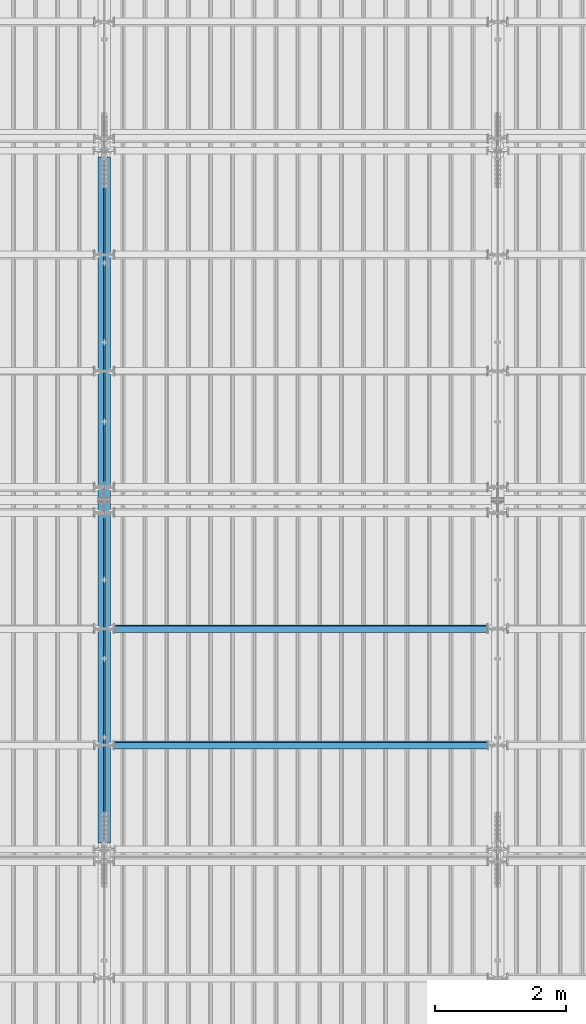
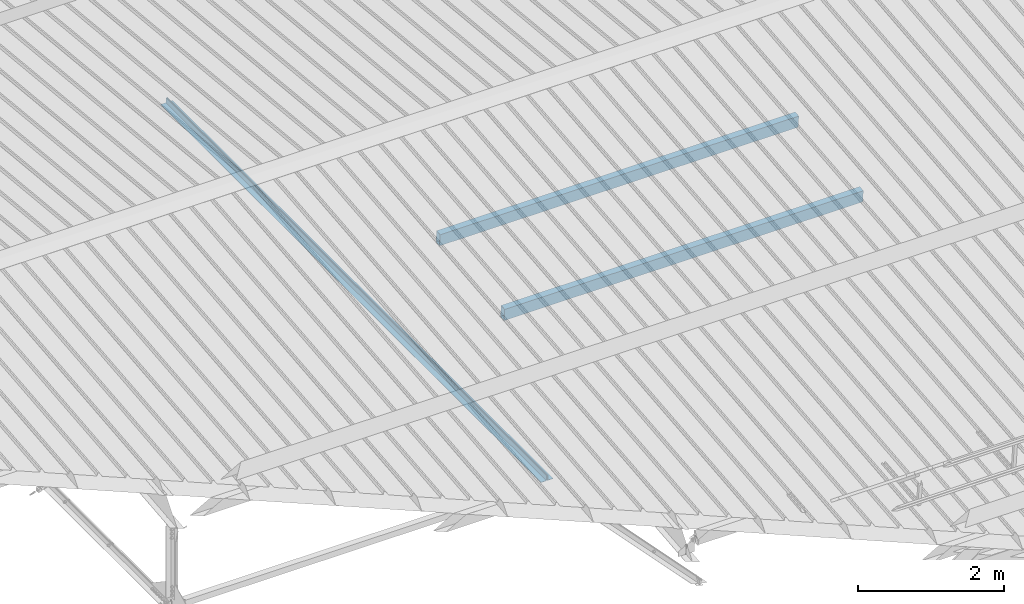
# One storey, part 256 of 709: 4 beams, 4 elements without a shape of their own.
"""IFC4 building model written with IfcOpenShell, lengths in millimetres."""

from ifc_helpers import new_model, si_unit, direction, frame, origin_with_axes, place, context, subcontext, project, spatial, polygons, material, element, aggregate, save


model = new_model("IFC4")

# Units and contexts
model_context = context("Model", 3, precision=0.2, world=origin_with_axes(), true_north=direction((0.0, 1.0)))
body_context = subcontext(model_context, "Body", "Model", "MODEL_VIEW")
ifc_project = project(units=[si_unit("LENGTHUNIT", "METRE", prefix="MILLI"), si_unit("AREAUNIT", "SQUARE_METRE"), si_unit("VOLUMEUNIT", "CUBIC_METRE"), si_unit("MASSUNIT", "GRAM", prefix="KILO"), si_unit("TIMEUNIT", "SECOND"), si_unit("PLANEANGLEUNIT", "RADIAN"), si_unit("SOLIDANGLEUNIT", "STERADIAN"), si_unit("THERMODYNAMICTEMPERATUREUNIT", "DEGREE_CELSIUS"), si_unit("LUMINOUSINTENSITYUNIT", "LUMEN")], contexts=[model_context])

# Site, building, storey
site_placement = place(None, origin_with_axes())
site = spatial("IfcSite", under=ifc_project, at=site_placement, CompositionType="ELEMENT")
building_placement = place(site_placement, origin_with_axes())
building = spatial("IfcBuilding", under=site, at=building_placement, Name="Undefined", CompositionType="ELEMENT")
storey_placement = place(building_placement, origin_with_axes())
storey = spatial("IfcBuildingStorey", under=building, at=storey_placement, Name="Undefined", CompositionType="ELEMENT", Elevation=0.0)

# Assembly, beam
assembly_1_placement = place(storey_placement, frame((15949.0, 5673.0, 6045.00002), z_axis=(0.0, 0.0, 1.0), x_axis=(0.0, 1.0, 0.0)))
assembly_1 = element("IfcElementAssembly", 1, at=assembly_1_placement, inside=storey)
ifc_material_1 = material(Name="C345-5", Category="STEEL")
beam_1_placement = place(assembly_1_placement, origin_with_axes())
beam_1 = element("IfcBeam", 2, at=beam_1_placement, material=ifc_material_1, ObjectType="433", context=body_context, shape_type="Tessellation", body=[
    polygons([(100.0, -45.0, -45.0), (100.0, 45.0, -45.0), (10554.0, 45.0, -45.0), (10554.0, -45.0, -45.0), (100.0, 45.0, -39.0), (10554.0, 45.0, -39.0), (100.0, -39.0, -39.0), (10554.0, -39.0, -39.0), (100.0, -39.0, 45.0), (10554.0, -39.0, 45.0), (100.0, -45.0, 45.0), (10554.0, -45.0, 45.0)], [[[1, 2, 3, 4]], [[2, 5, 6, 3]], [[5, 7, 8, 6]], [[7, 9, 10, 8]], [[9, 11, 12, 10]], [[11, 1, 4, 12]], [[6, 8, 10, 12, 4, 3]], [[11, 9, 7, 5, 2, 1]]], closed=True),
])
aggregate(assembly_1, [beam_1])

assembly_2_placement = place(storey_placement, frame((16051.0, 16327.0, 6045.00002), z_axis=(0.0, 0.0, 1.0), x_axis=(0.0, -1.0, 0.0)))
assembly_2 = element("IfcElementAssembly", 3, at=assembly_2_placement, inside=storey)
beam_2_placement = place(assembly_2_placement, origin_with_axes())
beam_2 = element("IfcBeam", 4, at=beam_2_placement, material=ifc_material_1, ObjectType="434", context=body_context, shape_type="Tessellation", body=[
    polygons([(100.0, -45.0, -45.0), (100.0, 45.0, -45.0), (10554.0, 45.0, -45.0), (10554.0, -45.0, -45.0), (100.0, 45.0, -39.0), (10554.0, 45.0, -39.0), (100.0, -39.0, -39.0), (10554.0, -39.0, -39.0), (100.0, -39.0, 45.0), (10554.0, -39.0, 45.0), (100.0, -45.0, 45.0), (10554.0, -45.0, 45.0)], [[[1, 2, 3, 4]], [[2, 5, 6, 3]], [[5, 7, 8, 6]], [[7, 9, 10, 8]], [[9, 11, 12, 10]], [[11, 1, 4, 12]], [[6, 8, 10, 12, 4, 3]], [[11, 9, 7, 5, 2, 1]]], closed=True),
])
aggregate(assembly_2, [beam_2])

assembly_3_placement = place(storey_placement, frame((16000.0, 7263.34988, 7854.7991), z_axis=(0.0, 0.9950371902, 0.099503719), x_axis=(1.0, 0.0, 0.0)))
assembly_3 = element("IfcElementAssembly", 5, at=assembly_3_placement, inside=storey)
ifc_material_2 = material(Name="C355", Category="STEEL")
beam_3_placement = place(assembly_3_placement, origin_with_axes())
beam_3 = element("IfcBeam", 6, at=beam_3_placement, material=ifc_material_2, ObjectType="579", context=body_context, shape_type="Tessellation", body=[
    polygons([(155.0, -96.0, -46.0), (155.0, -96.0, 46.0), (5845.0, -96.0, 46.0), (5845.0, -96.0, -46.0), (155.0, 96.0, 46.0), (5845.0, 96.0, 46.0), (155.0, 96.0, -46.0), (5845.0, 96.0, -46.0), (155.0, -100.0, -50.0), (155.0, 100.0, -50.0), (5845.0, 100.0, -50.0), (5845.0, -100.0, -50.0), (155.0, 100.0, 50.0), (5845.0, 100.0, 50.0), (155.0, -100.0, 50.0), (5845.0, -100.0, 50.0)], [[[1, 2, 3, 4]], [[2, 5, 6, 3]], [[5, 7, 8, 6]], [[7, 1, 4, 8]], [[9, 10, 11, 12]], [[10, 13, 14, 11]], [[13, 15, 16, 14]], [[15, 9, 12, 16]], [[14, 16, 12, 11], [6, 8, 4, 3]], [[15, 13, 10, 9], [7, 5, 2, 1]]], closed=True),
])
aggregate(assembly_3, [beam_3])

assembly_4_placement = place(storey_placement, frame((16000.0, 9036.65012, 8032.12913), z_axis=(0.0, 0.9950371902, 0.099503719), x_axis=(1.0, 0.0, 0.0)))
assembly_4 = element("IfcElementAssembly", 7, at=assembly_4_placement, inside=storey)
beam_4_placement = place(assembly_4_placement, origin_with_axes())
beam_4 = element("IfcBeam", 8, at=beam_4_placement, material=ifc_material_2, ObjectType="579", context=body_context, shape_type="Tessellation", body=[
    polygons([(155.0, -96.0, -46.0), (155.0, -96.0, 46.0), (5845.0, -96.0, 46.0), (5845.0, -96.0, -46.0), (155.0, 96.0, 46.0), (5845.0, 96.0, 46.0), (155.0, 96.0, -46.0), (5845.0, 96.0, -46.0), (155.0, -100.0, -50.0), (155.0, 100.0, -50.0), (5845.0, 100.0, -50.0), (5845.0, -100.0, -50.0), (155.0, 100.0, 50.0), (5845.0, 100.0, 50.0), (155.0, -100.0, 50.0), (5845.0, -100.0, 50.0)], [[[1, 2, 3, 4]], [[2, 5, 6, 3]], [[5, 7, 8, 6]], [[7, 1, 4, 8]], [[9, 10, 11, 12]], [[10, 13, 14, 11]], [[13, 15, 16, 14]], [[15, 9, 12, 16]], [[14, 16, 12, 11], [6, 8, 4, 3]], [[15, 13, 10, 9], [7, 5, 2, 1]]], closed=True),
])
aggregate(assembly_4, [beam_4])

save(model, "model.ifc")
